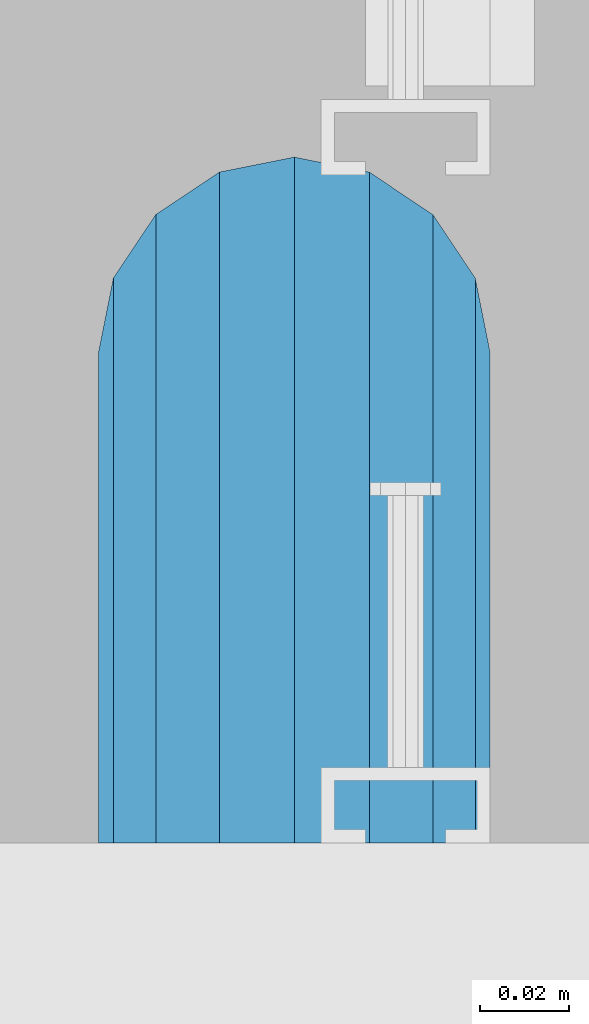
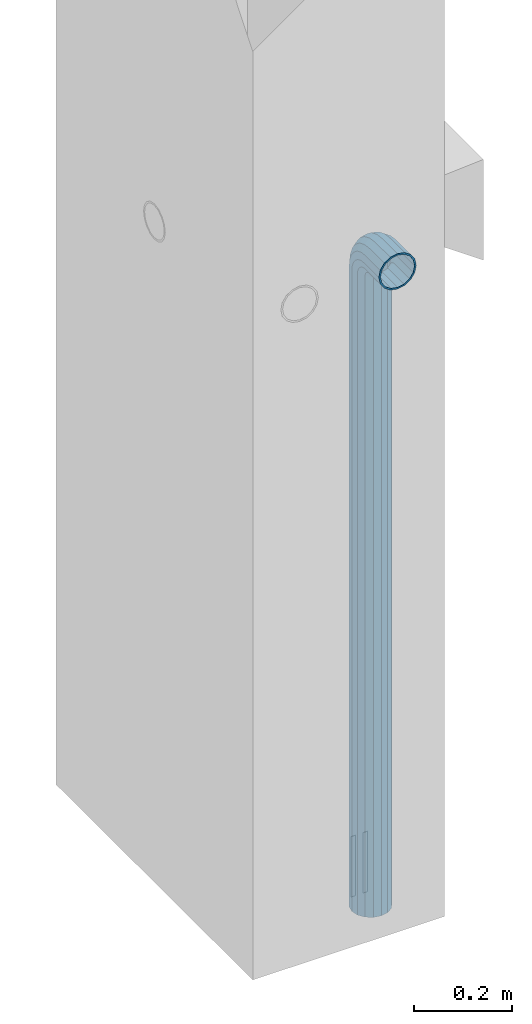
# One storey, part 6 of 41: 1 beam, 2 elements without a shape of their own.
"""IFC2X3 building model written with IfcOpenShell, lengths in millimetres."""

from ifc_helpers import new_model, si_unit, frame, origin_with_axes, place, context, subcontext, project, spatial, faceted_brep, material, type_object, element, aggregate, save


model = new_model("IFC2X3")

# Units and contexts
model_context = context("Model", 3, precision=1e-05, world=origin_with_axes())
body_context = subcontext(model_context, "Body", "Model", "MODEL_VIEW")
ifc_project = project(units=[si_unit("LENGTHUNIT", "METRE", prefix="MILLI"), si_unit("AREAUNIT", "SQUARE_METRE"), si_unit("VOLUMEUNIT", "CUBIC_METRE"), si_unit("MASSUNIT", "GRAM", prefix="KILO"), si_unit("TIMEUNIT", "SECOND"), si_unit("PLANEANGLEUNIT", "RADIAN"), si_unit("SOLIDANGLEUNIT", "STERADIAN"), si_unit("THERMODYNAMICTEMPERATUREUNIT", "DEGREE_CELSIUS"), si_unit("LUMINOUSINTENSITYUNIT", "LUMEN")], contexts=[model_context])

# Site, building, storey
site_placement = place(None, frame((-177556.685383467, -198018.589999756, 1290.0), z_axis=(0.0, 0.0, 1.0), x_axis=(0.788225611989142, -0.615386370180835, 0.0)))
site = spatial("IfcSite", under=ifc_project, at=site_placement, CompositionType="ELEMENT")
building_placement = place(site_placement, origin_with_axes())
building = spatial("IfcBuilding", under=site, at=building_placement, Name="Undefined", CompositionType="ELEMENT")
storey_placement = place(building_placement, origin_with_axes())
storey = spatial("IfcBuildingStorey", under=building, at=storey_placement, Name="Undefined", CompositionType="ELEMENT", Elevation=0.0)

# Assemblies, beam
assembly_1_placement = place(storey_placement, origin_with_axes())
assembly_1 = element("IfcElementAssembly", 1, at=assembly_1_placement, inside=storey, AssemblyPlace="NOTDEFINED", PredefinedType="REINFORCEMENT_UNIT")
assembly_2_placement = place(assembly_1_placement, origin_with_axes())
assembly_2 = element("IfcElementAssembly", 2, at=assembly_2_placement, AssemblyPlace="NOTDEFINED", PredefinedType="RIGID_FRAME")
aggregate(assembly_1, [assembly_2])
ifc_material = material(Name="STEEL/NEG_BETON")
beam_type = type_object("IfcBeamType", PredefinedType="NOTDEFINED")
beam_placement = place(assembly_2_placement, frame((18365.8936635989, 265191.472412349, -1290.0), z_axis=(0.615386370178831, -0.788225611990706, 0.0), x_axis=(0.0, 0.0, 1.0)))
beam = element("IfcBeam", 3, at=beam_placement, type_object=beam_type, material=ifc_material, context=body_context, shape_type="Brep", body=[
    faceted_brep([(0.0, -43.999999753345, 2.88331648334861e-07), (0.0, -40.6506991838105, -16.8380707357428), (1590.0, -40.6506991838105, -16.8380707357428), (1589.99999999999, -43.999999753345, 2.88331648334861e-07), (0.0, -31.1126981254783, -31.1126980838017), (1590.0, -31.1126981254783, -31.1126980838017), (0.0, -16.8380707773322, -40.6506991419883), (1590.0, -16.8380707773322, -40.6506991419883), (0.0, 2.46742274612188e-07, -43.9999997114064), (1590.0, 2.46742274612188e-07, -43.9999997114064), (0.0, 16.8380712707876, -40.6506991418137), (1590.0, 16.8380712707876, -40.6506991418137), (0.0, 31.1126986189047, -31.1126980834524), (1590.0, 31.1126986189047, -31.1126980834524), (0.0, 40.6506996771204, -16.8380707352771), (1590.0, 40.6506996771204, -16.8380707352771), (0.0, 44.0000002465677, 2.88768205791712e-07), (1590.0, 44.0000002465677, 2.88768205791712e-07), (0.0, 40.6506996770622, 16.8380713128427), (1590.0, 40.6506996770622, 16.8380713128427), (0.0, 31.1126986187301, 31.1126986609306), (1590.0, 31.1126986187301, 31.1126986609306), (0.0, 16.8380712705839, 40.6506997191464), (1590.0, 16.8380712705839, 40.6506997191464), (0.0, 2.46509443968534e-07, 44.0000002885354), (1590.0, 2.46509443968534e-07, 44.0000002885354), (0.0, -16.8380707775359, 40.6506997189426), (1590.0, -16.8380707775359, 40.6506997189426), (0.0, -31.1126981256821, 31.1126986605814), (1590.0, -31.1126981256821, 31.1126986605814), (0.0, -40.6506991838978, 16.838071312377), (1590.0, -40.6506991838978, 16.838071312377), (4.47878846898675e-07, -40.0000000634464, 0.0), (4.47878846898675e-07, -36.9551813638827, 15.3073372946019), (1590.0, -36.9551810538396, 15.3073375829845), (1589.99999999999, -39.999999753345, 2.88360752165318e-07), (4.47937054559588e-07, -28.2842713108694, 28.284271247463), (1590.0, -28.2842710008845, 28.2842715359002), (4.4800981413573e-07, -15.3073373580119, 36.9551813004509), (1590.0, -15.3073370480561, 36.9551815889135), (4.48068021796644e-07, -6.34463503956795e-08, 40.0), (1590.0, 2.46538547798991e-07, 40.0000002885645), (4.48140781372786e-07, 15.3073372311774, 36.9551813004509), (1590.0, 15.3073375411332, 36.9551815890882), (4.48213540948927e-07, 28.2842711840058, 28.284271247463), (1590.0, 28.2842714939907, 28.2842715361621), (4.48271748609841e-07, 36.95518123699, 15.3073372946019), (1590.0, 36.9551815469749, 15.3073375833046), (4.48286300525069e-07, 39.9999999365536, 0.0), (1590.0, 40.0000002465677, 2.88768205791712e-07), (4.48271748609841e-07, 36.95518123699, -15.3073372946019), (1590.0, 36.9551815470913, -15.3073370058555), (4.48213540948927e-07, 28.2842711840058, -28.284271247463), (1590.0, 28.2842714941071, -28.2842709587712), (4.48140781372786e-07, 15.3073372311774, -36.9551813004509), (1590.0, 15.3073375413369, -36.9551810117846), (4.48068021796644e-07, -6.34463503956795e-08, -40.0), (1590.0, 2.46742274612188e-07, -39.9999997114064), (4.4800981413573e-07, -15.3073373580119, -36.9551813004509), (1590.0, -15.3073370479106, -36.9551810119592), (4.47937054559588e-07, -28.2842713108694, -28.284271247463), (1590.0, -28.284271000739, -28.2842709590332), (4.47878846898675e-07, -36.9551813638827, -15.3073372946019), (1590.0, -36.9551810537523, -15.3073370062048), (1602.94095225512, -43.9999997540726, 1.70370897403336), (1598.5829387913, -40.6506991846254, 17.9680366410757), (1594.88839337186, -31.1126981263515, 31.7562678573595), (1592.41977704577, -16.8380707782635, 40.9692694107944), (1591.55291427061, 2.45810952037573e-07, 44.2044453310082), (1592.41977704577, 16.8380712698563, 40.969269410969), (1594.88839337186, 31.1126986180025, 31.7562678576505), (1598.5829387913, 40.6506996763346, 17.9680366415123), (1602.94095225512, 44.0000002458692, 1.70370897452813), (1607.29896571893, 40.6506996763928, -14.5606186925434), (1610.99351113838, 31.112698618148, -28.3488499088271), (1613.46212746447, 16.83807127006, -37.561851462262), (1614.32899023963, 2.4601467885077e-07, -40.7970273824176), (1613.46212746447, -16.8380707780307, -37.5618514623784), (1610.99351113838, -31.1126981262059, -28.348849909089), (1607.29896571893, -40.650699184509, -14.5606186929217), (1613.29371405922, 2.45985575020313e-07, -36.9333240772539), (1612.50565699089, 15.3073375405802, -33.9922550588963), (1610.26146033081, 28.2842714934086, -25.6167991012626), (1606.90278267677, 36.9551815463637, -13.0820434500929), (1602.94095225512, 40.0000002458692, 1.70370897449902), (1598.97912183347, 36.9551815463055, 16.4894613990327), (1595.62044417943, 28.2842714932631, 29.024217050086), (1593.37624751934, 15.3073375403765, 37.3996730076324), (1592.58819045102, 2.45781848207116e-07, 40.3407420258154), (1593.37624751934, -15.3073370488128, 37.3996730074577), (1595.62044417943, -28.2842710016412, 29.0242170498241), (1598.97912183347, -36.9551810545672, 16.4894613986544), (1602.94095225512, -39.9999997540726, 1.70370897406247), (1606.90278267677, -36.955181054509, -13.0820434504712), (1610.26146033081, -28.2842710014374, -25.6167991015245), (1612.50565699089, -15.307337048609, -33.9922550590418), (1630.55634918609, 31.112698618148, -20.2456570709182), (1635.32534971524, 16.8380712700309, -28.5058082887845), (1623.41903551202, 40.6506996764219, -7.883467157837), (1614.99999999999, 44.0000002458692, 6.69873009974253), (1606.58096448796, 40.6506996763346, 21.2809273572639), (1599.44365081389, 31.1126986180025, 33.6431172702578), (1594.67465028474, 16.8380712698563, 41.9032684879785), (1592.99999999999, 2.45752744376659e-07, 44.8038478659873), (1594.67465028474, -16.8380707782635, 41.9032684878039), (1599.44365081389, -31.1126981263515, 33.6431172699668), (1606.58096448796, -40.6506991846254, 21.2809273568855), (1614.99999999999, -43.9999997540726, 6.69873009927687), (1623.41903551202, -40.6506991845672, -7.88346715827356), (1630.55634918609, -31.1126981262059, -20.2456570712384), (1635.32534971524, -16.8380707780598, -28.5058082889591), (1636.99999999999, 2.45956471189857e-07, -31.4063876669679), (1633.47759065022, -15.3073370486381, -25.3053957082157), (1634.99999999999, 2.45985575020313e-07, -27.9422860518389), (1629.14213562372, -28.2842710014665, -17.7961673284299), (1622.65366864729, -36.9551810545381, -6.55781286209822), (1614.99999999999, -39.9999997541017, 6.69873009933508), (1607.34633135269, -36.9551810545381, 19.9552730607684), (1600.85786437626, -28.2842710016121, 31.1936275271582), (1596.52240934976, -15.3073370487837, 38.7028559070604), (1594.99999999999, 2.45810952037573e-07, 41.3397462508583), (1596.52240934976, 15.3073375404056, 38.702855907206), (1600.85786437626, 28.2842714932631, 31.1936275275075), (1607.34633135269, 36.9551815462473, 19.9552730610885), (1614.99999999999, 40.0000002458692, 6.69873009974253), (1622.65366864729, 36.9551815463346, -6.55781286169076), (1629.14213562372, 28.2842714933795, -17.7961673281679), (1633.47759065022, 15.3073375405511, -25.305395708041), (1647.35533905931, 31.1126986181189, -7.35533877040143), (1654.09972428659, 16.8380712700018, -14.0997239977587), (1637.26165326252, 40.6506996763928, 2.73834702643217), (1625.35533905931, 44.0000002458401, 14.6446612296568), (1613.4490248561, 40.6506996763346, 26.5509754328523), (1603.35533905931, 31.1126986179734, 36.6446612295404), (1596.61095383203, 16.8380712698563, 43.3890464567812), (1594.24264068711, 2.45810952037573e-07, 45.7573596016155), (1596.61095383203, -16.8380707782344, 43.3890464565775), (1603.35533905931, -31.1126981263806, 36.6446612292202), (1613.4490248561, -40.6506991846254, 26.5509754324157), (1625.35533905931, -43.9999997541017, 14.644661229162), (1637.26165326252, -40.6506991845672, 2.73834702599561), (1647.35533905931, -31.1126981262641, -7.35533877075068), (1654.09972428659, -16.838070778118, -14.0997239979333), (1656.46803743151, 2.45956471189857e-07, -16.4680371427676), (1651.48659835683, -15.3073370486381, -11.4865980681498), (1653.63961030677, 2.45956471189857e-07, -13.6396100180573), (1645.35533905931, -28.2842710015248, -5.35533877072157), (1636.17926106223, -36.955181054509, 3.82073922632844), (1625.35533905931, -39.9999997541017, 14.6446612291911), (1614.53141705639, -36.9551810545672, 25.4685832321702), (1605.35533905931, -28.2842710016121, 34.6446612292784), (1599.22407976179, -15.3073370487837, 40.775920526823), (1597.07106781185, 2.45781848207116e-07, 42.9289324768179), (1599.22407976179, 15.3073375403765, 40.7759205269977), (1605.35533905931, 28.2842714932631, 34.6446612295404), (1614.53141705639, 36.9551815462764, 25.4685832324903), (1625.35533905931, 40.0000002458401, 14.6446612296277), (1636.17926106223, 36.9551815463346, 3.82073922670679), (1645.35533905931, 28.2842714933795, -5.35533877045964), (1651.48659835683, 15.307337540522, -11.4865980680042), (1660.24565735981, 31.1126986180607, 9.44365110280341), (1668.50580857761, 16.8380712699436, 4.67465057360823), (1647.88346744676, 40.6506996763055, 16.5809647768911), (1633.3012701892, 44.000000245811, 25.0000002889719), (1618.71907293164, 40.6506996763055, 33.4190358009655), (1606.35688301859, 31.1126986179734, 40.5563494749367), (1598.09673180079, 16.8380712698563, 45.3253500040737), (1595.19615242269, 2.45781848207116e-07, 47.00000028871), (1598.09673180079, -16.8380707782635, 45.32535000387), (1606.35688301859, -31.1126981263806, 40.5563494746748), (1618.71907293164, -40.6506991846545, 33.419035800558), (1633.3012701892, -43.9999997541308, 25.0000002884772), (1647.88346744676, -40.6506991845963, 16.5809647764836), (1660.24565735981, -31.1126981262933, 9.44365110251238), (1668.50580857761, -16.8380707781762, 4.67465057340451), (1671.40638795571, 2.459273673594e-07, 3.00000028876821), (1665.30539599684, -15.3073370486964, 6.52240963847726), (1667.94228634057, 2.45898263528943e-07, 5.00000028876821), (1657.79616761703, -28.2842710015539, 10.8578646648966), (1646.55781315062, -36.9551810545672, 17.3463316412526), (1633.3012701892, -39.9999997541308, 25.0000002885063), (1620.04472722778, -36.9551810546254, 32.6536689358181), (1608.80637276137, -28.2842710016412, 39.1421359122905), (1601.29714438156, -15.3073370488128, 43.4775909388554), (1598.66025403783, 2.45781848207116e-07, 45.0000002886809), (1601.29714438156, 15.3073375403765, 43.4775909390009), (1608.80637276137, 28.2842714932631, 39.1421359125816), (1620.04472722778, 36.9551815462473, 32.6536689362256), (1633.3012701892, 40.0000002458401, 25.0000002889428), (1646.55781315062, 36.9551815463055, 17.346331641631), (1657.79616761703, 28.2842714933213, 10.8578646651586), (1665.30539599684, 15.3073375404638, 6.52240963859367), (1668.34885019768, 31.1126986180316, 29.0064891505172), (1677.56185175105, 16.8380712698563, 26.5378728243522), (1654.56061898146, 40.6506996763055, 32.7010345700255), (1638.29629131443, 44.0000002457818, 37.0590480338433), (1622.0319636474, 40.6506996763055, 41.4170614976319), (1608.24373243118, 31.1126986179734, 45.1116069169948), (1599.03073087781, 16.8380712698563, 47.5802232430142), (1595.79555495772, 2.45781848207116e-07, 48.4470860181027), (1599.03073087781, -16.8380707782635, 47.5802232428396), (1608.24373243118, -31.1126981263806, 45.1116069167037), (1622.0319636474, -40.6506991846836, 41.4170614971954), (1638.29629131443, -43.9999997541599, 37.0590480333485), (1654.56061898146, -40.6506991846254, 32.701034569589), (1668.34885019768, -31.1126981263515, 29.006489150197), (1677.56185175105, -16.8380707782053, 26.5378728241776), (1680.79702767114, 2.4584005586803e-07, 25.6710100491182), (1673.99225534772, -15.3073370487546, 27.4943432977598), (1676.93332436598, 2.4584005586803e-07, 26.7062862295134), (1665.61679939011, -28.284271001583, 29.7385399577906), (1653.082043739, -36.9551810545963, 33.0972176117939), (1638.29629131443, -39.9999997541599, 37.0590480334067), (1623.51053888986, -36.9551810546545, 41.0208784550487), (1610.97578323875, -28.2842710016412, 44.3795561091392), (1602.60032728114, -15.3073370487837, 46.6237527692865), (1599.65925826287, 2.45810952037573e-07, 47.4118098377076), (1602.60032728114, 15.3073375403474, 46.623752769432), (1610.97578323875, 28.284271493234, 44.3795561094012), (1623.51053888986, 36.9551815462182, 41.0208784554561), (1638.29629131443, 40.0000002457818, 37.0590480338142), (1653.082043739, 36.9551815462473, 33.097217612114), (1665.61679939011, 28.2842714932631, 29.7385399580817), (1673.99225534772, 15.3073375404347, 27.4943432979344), (1671.11269837217, -31.1126981263806, 50.0000002885645), (1656.83807102403, -40.6506991847127, 50.0000002885063), (1680.65069943045, -16.8380707782635, 50.0000002886227), (1683.99999999996, 2.45781848207116e-07, 50.0000002887391), (1680.65069943045, 16.8380712698563, 50.0000002887973), (1671.11269837217, 31.1126986179734, 50.0000002888555), (1656.83807102403, 40.6506996762473, 50.0000002889428), (1639.99999999997, 44.0000002457236, 50.0000002889137), (1623.16192897591, 40.6506996762473, 50.0000002889428), (1608.88730162777, 31.1126986179734, 50.0000002888555), (1599.34930056949, 16.8380712698563, 50.0000002887973), (1595.99999999998, 2.45781848207116e-07, 50.0000002887391), (1599.34930056949, -16.8380707782635, 50.0000002886227), (1608.88730162777, -31.1126981263806, 50.0000002885645), (1623.16192897591, -40.6506991846836, 50.0000002885063), (1640.0, -43.999999754189, 50.0000002885063), (1676.95518130041, -15.3073370488128, 50.0000002886227), (1679.99999999996, 2.45781848207116e-07, 50.0000002887391), (1668.28427124742, -28.2842710016703, 50.0000002885645), (1655.30733729457, -36.9551810546545, 50.0000002885354), (1640.0, -39.999999754189, 50.0000002885063), (1624.69266270537, -36.9551810546545, 50.0000002885354), (1611.71572875252, -28.2842710016703, 50.0000002885645), (1603.04481869953, -15.3073370488128, 50.0000002886227), (1599.99999999998, 2.45781848207116e-07, 50.0000002887391), (1603.04481869953, 15.3073375403765, 50.0000002887973), (1611.71572875252, 28.284271493234, 50.0000002888555), (1624.69266270537, 36.9551815461891, 50.0000002888846), (1639.99999999997, 40.0000002457236, 50.0000002889137), (1655.30733729457, 36.9551815461891, 50.0000002889137), (1668.28427124742, 28.284271493234, 50.0000002888555), (1676.95518130041, 15.3073375403765, 50.0000002887973), (1656.83807102406, -40.6506991848582, 110.000000288477), (1640.0, -43.9999997543346, 110.000000288477), (1671.11269837221, -31.1126981265552, 110.000000288535), (1680.6506994305, -16.838070778409, 110.000000288594), (1684.0, 2.45607225224376e-07, 110.00000028871), (1680.6506994305, 16.8380712696817, 110.000000288768), (1671.11269837221, 31.1126986177987, 110.000000288826), (1656.83807102406, 40.6506996761018, 110.000000288914), (1640.0, 44.0000002455781, 110.000000288914), (1623.16192897594, 40.6506996761018, 110.000000288914), (1608.88730162779, 31.1126986177987, 110.000000288826), (1599.3493005695, 16.8380712696817, 110.000000288768), (1596.0, 2.45607225224376e-07, 110.00000028871), (1599.3493005695, -16.838070778409, 110.000000288594), (1608.88730162779, -31.1126981265552, 110.000000288535), (1623.16192897594, -40.6506991848582, 110.000000288477), (1624.6926627054, -36.9551810548001, 110.000000288535), (1640.0, -39.9999997543346, 110.000000288477), (1611.71572875254, -28.2842710018158, 110.000000288535), (1603.04481869955, -15.3073370489583, 110.000000288594), (1600.0, 2.45607225224376e-07, 110.00000028871), (1603.04481869955, 15.3073375402309, 110.000000288768), (1611.71572875254, 28.2842714930885, 110.000000288856), (1624.6926627054, 36.9551815460436, 110.000000288856), (1640.0, 40.0000002455781, 110.000000288885), (1655.3073372946, 36.9551815460436, 110.000000288856), (1668.28427124746, 28.2842714930885, 110.000000288856), (1676.95518130045, 15.3073375402309, 110.000000288768), (1680.0, 2.45607225224376e-07, 110.00000028871), (1676.95518130045, -15.3073370489583, 110.000000288594), (1668.28427124746, -28.2842710018158, 110.000000288535), (1655.3073372946, -36.9551810548001, 110.000000288535)], [[[0, 1, 2, 3]], [[1, 4, 5, 2]], [[4, 6, 7, 5]], [[6, 8, 9, 7]], [[8, 10, 11, 9]], [[10, 12, 13, 11]], [[12, 14, 15, 13]], [[14, 16, 17, 15]], [[16, 18, 19, 17]], [[18, 20, 21, 19]], [[20, 22, 23, 21]], [[22, 24, 25, 23]], [[24, 26, 27, 25]], [[26, 28, 29, 27]], [[28, 30, 31, 29]], [[30, 0, 3, 31]], [[32, 33, 34, 35]], [[33, 36, 37, 34]], [[36, 38, 39, 37]], [[38, 40, 41, 39]], [[40, 42, 43, 41]], [[42, 44, 45, 43]], [[44, 46, 47, 45]], [[46, 48, 49, 47]], [[48, 50, 51, 49]], [[50, 52, 53, 51]], [[52, 54, 55, 53]], [[54, 56, 57, 55]], [[56, 58, 59, 57]], [[58, 60, 61, 59]], [[60, 62, 63, 61]], [[62, 32, 35, 63]], [[30, 28, 26, 24, 22, 20, 18, 16, 14, 12, 10, 8, 6, 4, 1, 0], [62, 60, 58, 56, 54, 52, 50, 48, 46, 44, 42, 40, 38, 36, 33, 32]], [[31, 3, 64, 65]], [[29, 31, 65, 66]], [[27, 29, 66, 67]], [[25, 27, 67, 68]], [[23, 25, 68, 69]], [[21, 23, 69, 70]], [[19, 21, 70, 71]], [[17, 19, 71, 72]], [[15, 17, 72, 73]], [[13, 15, 73, 74]], [[11, 13, 74, 75]], [[9, 11, 75, 76]], [[7, 9, 76, 77]], [[5, 7, 77, 78]], [[2, 5, 78, 79]], [[3, 2, 79, 64]], [[55, 57, 80, 81]], [[53, 55, 81, 82]], [[51, 53, 82, 83]], [[49, 51, 83, 84]], [[47, 49, 84, 85]], [[45, 47, 85, 86]], [[43, 45, 86, 87]], [[41, 43, 87, 88]], [[39, 41, 88, 89]], [[37, 39, 89, 90]], [[34, 37, 90, 91]], [[35, 34, 91, 92]], [[63, 35, 92, 93]], [[61, 63, 93, 94]], [[59, 61, 94, 95]], [[57, 59, 95, 80]], [[74, 96, 97, 75]], [[73, 98, 96, 74]], [[72, 99, 98, 73]], [[71, 100, 99, 72]], [[70, 101, 100, 71]], [[69, 102, 101, 70]], [[68, 103, 102, 69]], [[67, 104, 103, 68]], [[66, 105, 104, 67]], [[65, 106, 105, 66]], [[64, 107, 106, 65]], [[79, 108, 107, 64]], [[78, 109, 108, 79]], [[77, 110, 109, 78]], [[76, 111, 110, 77]], [[75, 97, 111, 76]], [[95, 112, 113, 80]], [[94, 114, 112, 95]], [[93, 115, 114, 94]], [[92, 116, 115, 93]], [[91, 117, 116, 92]], [[90, 118, 117, 91]], [[89, 119, 118, 90]], [[88, 120, 119, 89]], [[87, 121, 120, 88]], [[86, 122, 121, 87]], [[85, 123, 122, 86]], [[84, 124, 123, 85]], [[83, 125, 124, 84]], [[82, 126, 125, 83]], [[81, 127, 126, 82]], [[80, 113, 127, 81]], [[96, 128, 129, 97]], [[98, 130, 128, 96]], [[99, 131, 130, 98]], [[100, 132, 131, 99]], [[101, 133, 132, 100]], [[102, 134, 133, 101]], [[103, 135, 134, 102]], [[104, 136, 135, 103]], [[105, 137, 136, 104]], [[106, 138, 137, 105]], [[107, 139, 138, 106]], [[108, 140, 139, 107]], [[109, 141, 140, 108]], [[110, 142, 141, 109]], [[111, 143, 142, 110]], [[97, 129, 143, 111]], [[112, 144, 145, 113]], [[114, 146, 144, 112]], [[115, 147, 146, 114]], [[116, 148, 147, 115]], [[117, 149, 148, 116]], [[118, 150, 149, 117]], [[119, 151, 150, 118]], [[120, 152, 151, 119]], [[121, 153, 152, 120]], [[122, 154, 153, 121]], [[123, 155, 154, 122]], [[124, 156, 155, 123]], [[125, 157, 156, 124]], [[126, 158, 157, 125]], [[127, 159, 158, 126]], [[113, 145, 159, 127]], [[128, 160, 161, 129]], [[130, 162, 160, 128]], [[131, 163, 162, 130]], [[132, 164, 163, 131]], [[133, 165, 164, 132]], [[134, 166, 165, 133]], [[135, 167, 166, 134]], [[136, 168, 167, 135]], [[137, 169, 168, 136]], [[138, 170, 169, 137]], [[139, 171, 170, 138]], [[140, 172, 171, 139]], [[141, 173, 172, 140]], [[142, 174, 173, 141]], [[143, 175, 174, 142]], [[129, 161, 175, 143]], [[144, 176, 177, 145]], [[146, 178, 176, 144]], [[147, 179, 178, 146]], [[148, 180, 179, 147]], [[149, 181, 180, 148]], [[150, 182, 181, 149]], [[151, 183, 182, 150]], [[152, 184, 183, 151]], [[153, 185, 184, 152]], [[154, 186, 185, 153]], [[155, 187, 186, 154]], [[156, 188, 187, 155]], [[157, 189, 188, 156]], [[158, 190, 189, 157]], [[159, 191, 190, 158]], [[145, 177, 191, 159]], [[160, 192, 193, 161]], [[162, 194, 192, 160]], [[163, 195, 194, 162]], [[164, 196, 195, 163]], [[165, 197, 196, 164]], [[166, 198, 197, 165]], [[167, 199, 198, 166]], [[168, 200, 199, 167]], [[169, 201, 200, 168]], [[170, 202, 201, 169]], [[171, 203, 202, 170]], [[172, 204, 203, 171]], [[173, 205, 204, 172]], [[174, 206, 205, 173]], [[175, 207, 206, 174]], [[161, 193, 207, 175]], [[176, 208, 209, 177]], [[178, 210, 208, 176]], [[179, 211, 210, 178]], [[180, 212, 211, 179]], [[181, 213, 212, 180]], [[182, 214, 213, 181]], [[183, 215, 214, 182]], [[184, 216, 215, 183]], [[185, 217, 216, 184]], [[186, 218, 217, 185]], [[187, 219, 218, 186]], [[188, 220, 219, 187]], [[189, 221, 220, 188]], [[190, 222, 221, 189]], [[191, 223, 222, 190]], [[177, 209, 223, 191]], [[205, 224, 225, 204]], [[206, 226, 224, 205]], [[207, 227, 226, 206]], [[193, 228, 227, 207]], [[192, 229, 228, 193]], [[194, 230, 229, 192]], [[195, 231, 230, 194]], [[196, 232, 231, 195]], [[197, 233, 232, 196]], [[198, 234, 233, 197]], [[199, 235, 234, 198]], [[200, 236, 235, 199]], [[201, 237, 236, 200]], [[202, 238, 237, 201]], [[203, 239, 238, 202]], [[204, 225, 239, 203]], [[208, 240, 241, 209]], [[210, 242, 240, 208]], [[211, 243, 242, 210]], [[212, 244, 243, 211]], [[213, 245, 244, 212]], [[214, 246, 245, 213]], [[215, 247, 246, 214]], [[216, 248, 247, 215]], [[217, 249, 248, 216]], [[218, 250, 249, 217]], [[219, 251, 250, 218]], [[220, 252, 251, 219]], [[221, 253, 252, 220]], [[222, 254, 253, 221]], [[223, 255, 254, 222]], [[209, 241, 255, 223]], [[239, 225, 256, 257]], [[225, 224, 258, 256]], [[224, 226, 259, 258]], [[226, 227, 260, 259]], [[227, 228, 261, 260]], [[228, 229, 262, 261]], [[229, 230, 263, 262]], [[230, 231, 264, 263]], [[231, 232, 265, 264]], [[232, 233, 266, 265]], [[233, 234, 267, 266]], [[234, 235, 268, 267]], [[235, 236, 269, 268]], [[236, 237, 270, 269]], [[237, 238, 271, 270]], [[238, 239, 257, 271]], [[244, 245, 272, 273]], [[245, 246, 274, 272]], [[246, 247, 275, 274]], [[247, 248, 276, 275]], [[248, 249, 277, 276]], [[249, 250, 278, 277]], [[250, 251, 279, 278]], [[251, 252, 280, 279]], [[252, 253, 281, 280]], [[253, 254, 282, 281]], [[254, 255, 283, 282]], [[255, 241, 284, 283]], [[241, 240, 285, 284]], [[240, 242, 286, 285]], [[242, 243, 287, 286]], [[243, 244, 273, 287]], [[258, 259, 260, 261, 262, 263, 264, 265, 266, 267, 268, 269, 270, 271, 257, 256], [274, 275, 276, 277, 278, 279, 280, 281, 282, 283, 284, 285, 286, 287, 273, 272]]]),
])
aggregate(assembly_2, [beam])

save(model, "model.ifc")
